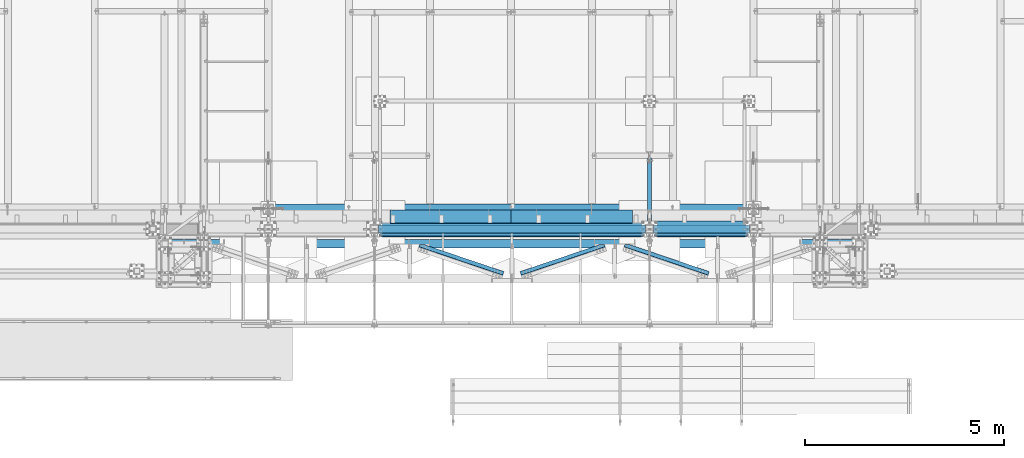
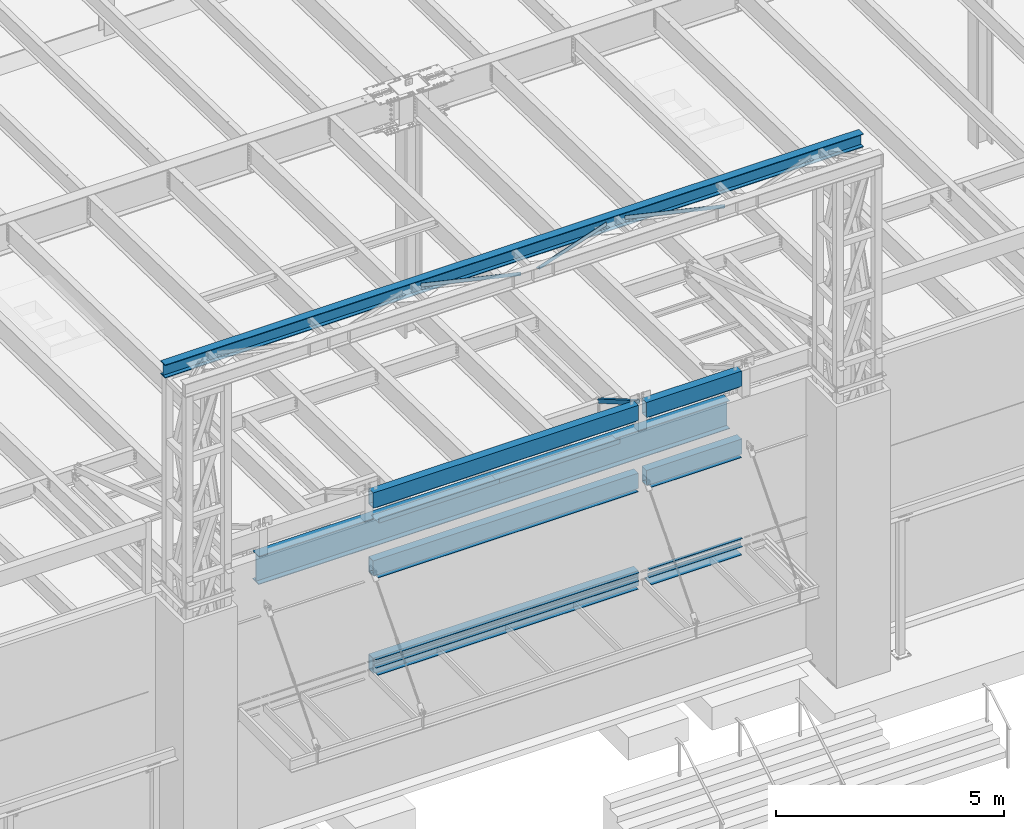
# One storey, part 1057 of 1763: 22 beams, 1 member, 12 elements without a shape of their own.
"""IFC2X3 building model written with IfcOpenShell, lengths in millimetres."""

from ifc_helpers import new_model, si_unit, frame, origin_with_axes, place, context, subcontext, project, spatial, faceted_brep, material, type_object, element, aggregate, save


model = new_model("IFC2X3")

# Units and contexts
model_context = context("Model", 3, precision=1e-05, world=origin_with_axes())
body_context = subcontext(model_context, "Body", "Model", "MODEL_VIEW")
ifc_project = project(units=[si_unit("LENGTHUNIT", "METRE", prefix="MILLI"), si_unit("AREAUNIT", "SQUARE_METRE"), si_unit("VOLUMEUNIT", "CUBIC_METRE"), si_unit("MASSUNIT", "GRAM", prefix="KILO"), si_unit("TIMEUNIT", "SECOND"), si_unit("PLANEANGLEUNIT", "RADIAN"), si_unit("SOLIDANGLEUNIT", "STERADIAN"), si_unit("THERMODYNAMICTEMPERATUREUNIT", "DEGREE_CELSIUS"), si_unit("LUMINOUSINTENSITYUNIT", "LUMEN")], contexts=[model_context])

# Site, building, storey
site_placement = place(None, origin_with_axes())
site = spatial("IfcSite", under=ifc_project, at=site_placement, CompositionType="ELEMENT")
building_placement = place(site_placement, origin_with_axes())
building = spatial("IfcBuilding", under=site, at=building_placement, Name="Undefined", CompositionType="ELEMENT")
storey_placement = place(building_placement, origin_with_axes())
storey = spatial("IfcBuildingStorey", under=building, at=storey_placement, Name="Undefined", CompositionType="ELEMENT", Elevation=0.0)

# Assembly, beam
assembly_1_placement = place(storey_placement, origin_with_axes())
assembly_1 = element("IfcElementAssembly", 1, at=assembly_1_placement, inside=storey, Name="BEAM", AssemblyPlace="NOTDEFINED", PredefinedType="RIGID_FRAME")
ifc_material_1 = material()
beam_type_1 = type_object("IfcBeamType", Name="HSS16X8X5/8", PredefinedType="NOTDEFINED")
beam_1_placement = place(assembly_1_placement, frame((-51917.027008321, -14208.1275869816, 13055.6221257957), z_axis=(0.0, 0.0, 1.0), x_axis=(1.0, 0.0, 0.0)))
beam_1 = element("IfcBeam", 2, at=beam_1_placement, type_object=beam_type_1, material=ifc_material_1, Name="BEAM", ObjectType="HSS16X8X5/8", context=body_context, shape_type="Brep", body=[
    faceted_brep([(0.0, 85.7250000000058, -187.325), (0.0, -85.7250000000058, -187.325), (2413.00000000001, -85.7250000000004, -187.325000000001), (2413.00000000001, 85.7250000000004, -187.325000000001), (0.0, -85.7250000000058, 187.325), (2413.00000000001, -85.7250000000004, 187.325000000001), (0.0, 85.7250000000058, 187.325), (2413.00000000001, 85.7250000000004, 187.325000000001), (0.0, 101.600000000006, -203.2), (0.0, 101.600000000006, 203.2), (2413.00000000001, 101.6, 203.200000000001), (2413.00000000001, 101.6, -203.200000000001), (0.0, -101.600000000006, 203.2), (2413.00000000001, -101.6, 203.200000000001), (0.0, -101.600000000006, -203.2), (2413.00000000001, -101.6, -203.200000000001)], [[[0, 1, 2, 3]], [[1, 4, 5, 2]], [[4, 6, 7, 5]], [[6, 0, 3, 7]], [[8, 9, 10, 11]], [[9, 12, 13, 10]], [[12, 14, 15, 13]], [[14, 8, 11, 15]], [[13, 15, 11, 10], [5, 7, 3, 2]], [[14, 12, 9, 8], [6, 4, 1, 0]]]),
])

assembly_2_placement = place(storey_placement, origin_with_axes())
assembly_2 = element("IfcElementAssembly", 3, at=assembly_2_placement, inside=storey, Name="BEAM", AssemblyPlace="NOTDEFINED", PredefinedType="RIGID_FRAME")
beam_2_placement = place(assembly_2_placement, frame((-58825.8276803548, -14208.1276214906, 13055.6221257968), z_axis=(3.29999999667052e-06, 0.0, 0.999999999994555), x_axis=(0.999999999994883, 4.99999977045952e-09, -3.19899999977773e-06)))
beam_2 = element("IfcBeam", 4, at=beam_2_placement, type_object=beam_type_1, material=ifc_material_1, Name="BEAM", ObjectType="HSS16X8X5/8", context=body_context, shape_type="Brep", body=[
    faceted_brep([(0.0, 85.7250000000058, -187.325), (0.0, -85.7250000000058, -187.325), (6705.60000152276, -85.7249999973046, -187.324999997729), (6705.60000152301, 85.7250000026943, -187.324999997732), (0.0, -85.7250000000058, 187.325), (6705.60000152401, -85.7249999973046, 187.325000002267), (0.0, 85.7250000000058, 187.325), (6705.60000152425, 85.7250000026943, 187.325000002264), (0.0, 101.600000000006, -203.2), (0.0, 101.600000000006, 203.2), (6705.60000152433, 101.600000002694, 203.200000002264), (6705.60000152298, 101.600000002694, -203.199999997731), (0.0, -101.600000000006, 203.2), (6705.60000152404, -101.599999997305, 203.200000002267), (0.0, -101.600000000006, -203.2), (6705.6000015227, -101.599999997305, -203.199999997727)], [[[0, 1, 2, 3]], [[1, 4, 5, 2]], [[4, 6, 7, 5]], [[6, 0, 3, 7]], [[8, 9, 10, 11]], [[9, 12, 13, 10]], [[12, 14, 15, 13]], [[14, 8, 11, 15]], [[13, 15, 11, 10], [5, 7, 3, 2]], [[14, 12, 9, 8], [6, 4, 1, 0]]]),
])

assembly_3_placement = place(storey_placement, origin_with_axes())
assembly_3 = element("IfcElementAssembly", 5, at=assembly_3_placement, inside=storey, Name="BEAM", AssemblyPlace="NOTDEFINED", PredefinedType="RIGID_FRAME")
beam_3_placement = place(assembly_3_placement, frame((-58825.8270098567, -14208.1276214906, 11239.5), z_axis=(0.0, 0.0, 1.0), x_axis=(1.0, 0.0, 0.0)))
beam_3 = element("IfcBeam", 6, at=beam_3_placement, type_object=beam_type_1, material=ifc_material_1, Name="BEAM", ObjectType="HSS16X8X5/8", context=body_context, shape_type="Brep", body=[
    faceted_brep([(0.0, 85.7250000000058, -187.325), (0.0, -85.7250000000058, -187.325), (6705.60000152276, -85.7249999973046, -187.324999997729), (6705.60000152301, 85.7250000026943, -187.324999997732), (0.0, -85.7250000000058, 187.325), (6705.60000152401, -85.7249999973046, 187.325000002267), (0.0, 85.7250000000058, 187.325), (6705.60000152425, 85.7250000026943, 187.325000002264), (0.0, 101.600000000006, -203.2), (0.0, 101.600000000006, 203.2), (6705.60000152433, 101.600000002694, 203.200000002264), (6705.60000152298, 101.600000002694, -203.199999997731), (0.0, -101.600000000006, 203.2), (6705.60000152404, -101.599999997305, 203.200000002267), (0.0, -101.600000000006, -203.2), (6705.6000015227, -101.599999997305, -203.199999997727)], [[[0, 1, 2, 3]], [[1, 4, 5, 2]], [[4, 6, 7, 5]], [[6, 0, 3, 7]], [[8, 9, 10, 11]], [[9, 12, 13, 10]], [[12, 14, 15, 13]], [[14, 8, 11, 15]], [[13, 15, 11, 10], [5, 7, 3, 2]], [[14, 12, 9, 8], [6, 4, 1, 0]]]),
])

assembly_4_placement = place(storey_placement, origin_with_axes())
assembly_4 = element("IfcElementAssembly", 7, at=assembly_4_placement, inside=storey, Name="BEAM", AssemblyPlace="NOTDEFINED", PredefinedType="RIGID_FRAME")
beam_4_placement = place(assembly_4_placement, frame((-58825.8270098567, -14208.1276214906, 8636.0), z_axis=(0.0, 0.0, 1.0), x_axis=(1.0, 0.0, 0.0)))
beam_4 = element("IfcBeam", 8, at=beam_4_placement, type_object=beam_type_1, material=ifc_material_1, Name="BEAM", ObjectType="HSS16X8X5/8", context=body_context, shape_type="Brep", body=[
    faceted_brep([(0.0, 85.7250000000058, -187.325), (0.0, -85.7250000000058, -187.325), (6705.60000152276, -85.7249999973046, -187.324999997729), (6705.60000152301, 85.7250000026943, -187.324999997732), (0.0, -85.7250000000058, 187.325), (6705.60000152401, -85.7249999973046, 187.325000002267), (0.0, 85.7250000000058, 187.325), (6705.60000152425, 85.7250000026943, 187.325000002264), (0.0, 101.600000000006, -203.2), (0.0, 101.600000000006, 203.2), (6705.60000152433, 101.600000002694, 203.200000002264), (6705.60000152298, 101.600000002694, -203.199999997731), (0.0, -101.600000000006, 203.2), (6705.60000152404, -101.599999997305, 203.200000002267), (0.0, -101.600000000006, -203.2), (6705.6000015227, -101.599999997305, -203.199999997727)], [[[0, 1, 2, 3]], [[1, 4, 5, 2]], [[4, 6, 7, 5]], [[6, 0, 3, 7]], [[8, 9, 10, 11]], [[9, 12, 13, 10]], [[12, 14, 15, 13]], [[14, 8, 11, 15]], [[13, 15, 11, 10], [5, 7, 3, 2]], [[14, 12, 9, 8], [6, 4, 1, 0]]]),
])

assembly_5_placement = place(storey_placement, origin_with_axes())
assembly_5 = element("IfcElementAssembly", 9, at=assembly_5_placement, inside=storey, Name="ANGLE", AssemblyPlace="NOTDEFINED", PredefinedType="RIGID_FRAME")
ifc_material_2 = material(Name="STEEL/A36")
beam_type_2 = type_object("IfcBeamType", Name="L4X4X1/4", PredefinedType="NOTDEFINED")
beam_5_placement = place(assembly_5_placement, frame((-52877.5798431206, -14531.4847231147, 18672.175), z_axis=(0.320655196883025, 0.947195990654473, 0.0), x_axis=(0.947195990654472, -0.320655196883028, 0.0)))
beam_5 = element("IfcBeam", 10, at=beam_5_placement, type_object=beam_type_2, material=ifc_material_2, Name="ANGLE", ObjectType="L4X4X1/4", context=body_context, shape_type="Brep", body=[
    faceted_brep([(248.960001879874, 44.4500000000007, 15.1976981958214), (248.960001879874, 50.7999999999993, 15.1976981958214), (248.955725224791, 50.7999999999993, -50.8000000003522), (248.955725224791, -50.7999999999993, -50.8000000003522), (248.956127270321, -50.7999999999993, -44.4500000003463), (248.956127270321, 44.4500000000007, -44.4500000003463), (354.602873441865, 44.4500000000007, 50.953844037489), (354.602873441872, 50.7999999999993, 50.7999999995773), (2474.00619453916, -50.7999999999993, -44.4500000031403), (2474.00578204374, -50.7999999999993, -50.8000000031461), (2474.00578204374, 50.7999999999993, -50.8000000031461), (2474.01238197072, 50.7999999999993, 50.7999999969179), (2474.01238197072, 44.4500000000007, 50.7999999969179), (2474.00619453916, 44.4500000000007, -44.4500000031403)], [[[0, 1, 2, 3, 4, 5]], [[6, 7, 1, 0]], [[8, 9, 10, 11, 12, 13]], [[5, 13, 12, 6, 0]], [[8, 13, 5, 4]], [[9, 8, 4, 3]], [[10, 9, 3, 2]], [[11, 10, 2, 1, 7]], [[12, 11, 7, 6]]]),
])
aggregate(assembly_5, [beam_5])

assembly_6_placement = place(storey_placement, origin_with_axes())
assembly_6 = element("IfcElementAssembly", 11, at=assembly_6_placement, inside=storey, Name="ANGLE", AssemblyPlace="NOTDEFINED", PredefinedType="RIGID_FRAME")
beam_6_placement = place(assembly_6_placement, frame((-58035.8965740268, -14531.4846908502, 18672.175), z_axis=(0.320655196883025, 0.947195990654473, 0.0), x_axis=(0.947195990654472, -0.320655196883028, 0.0)))
beam_6 = element("IfcBeam", 12, at=beam_6_placement, type_object=beam_type_2, material=ifc_material_2, Name="ANGLE", ObjectType="L4X4X1/4", context=body_context, shape_type="Brep", body=[
    faceted_brep([(248.960001879874, 44.4500000000007, 15.1976981958214), (248.960001879874, 50.7999999999993, 15.1976981958214), (248.955725224791, 50.7999999999993, -50.8000000003522), (248.955725224791, -50.7999999999993, -50.8000000003522), (248.956127270321, -50.7999999999993, -44.4500000003463), (248.956127270321, 44.4500000000007, -44.4500000003463), (354.602873441865, 44.4500000000007, 50.953844037489), (354.602873441872, 50.7999999999993, 50.7999999995773), (2474.00619453916, -50.7999999999993, -44.4500000031403), (2474.00578204374, -50.7999999999993, -50.8000000031461), (2474.00578204374, 50.7999999999993, -50.8000000031461), (2474.01238197072, 50.7999999999993, 50.7999999969179), (2474.01238197072, 44.4500000000007, 50.7999999969179), (2474.00619453916, 44.4500000000007, -44.4500000031403)], [[[0, 1, 2, 3, 4, 5]], [[6, 7, 1, 0]], [[8, 9, 10, 11, 12, 13]], [[5, 13, 12, 6, 0]], [[8, 13, 5, 4]], [[9, 8, 4, 3]], [[10, 9, 3, 2]], [[11, 10, 2, 1, 7]], [[12, 11, 7, 6]]]),
])
aggregate(assembly_6, [beam_6])

assembly_7_placement = place(storey_placement, origin_with_axes())
assembly_7 = element("IfcElementAssembly", 13, at=assembly_7_placement, inside=storey, Name="ANGLE", AssemblyPlace="NOTDEFINED", PredefinedType="RIGID_FRAME")
beam_7_placement = place(assembly_7_placement, frame((-55489.316785198, -15404.6097572214, 18672.175), z_axis=(-0.320655214854611, 0.947195984570534, 0.0), x_axis=(0.947195984570534, 0.320655214854612, 0.0)))
beam_7 = element("IfcBeam", 14, at=beam_7_placement, type_object=beam_type_2, material=ifc_material_2, Name="ANGLE", ObjectType="L4X4X1/4", context=body_context, shape_type="Brep", body=[
    faceted_brep([(2473.90666734029, 44.4500000000007, 14.9212591829789), (2473.90666734029, 50.7999999999993, 14.9212591829789), (2368.26819304615, 50.7999999999993, 50.8000000021136), (2368.26819304615, 44.4500000000007, 50.8000000021136), (2473.90322387923, 44.4500000000007, -44.4499999977991), (2473.90322387923, -50.7999999999993, -44.4499999977991), (2473.90284887469, -50.7999999999993, -50.7999999978013), (2473.90284887469, 50.7999999999993, -50.7999999978013), (248.852789269382, 50.7999999999993, -50.7999999997803), (248.852789269382, -50.7999999999993, -50.7999999997803), (248.853157555044, -50.7999999999993, -44.4499999997781), (248.853157555044, 44.4500000000007, -44.4499999997781), (248.858681840073, 44.4500000000007, 50.8000000002273), (248.858681840073, 50.7999999999993, 50.8000000002273)], [[[0, 1, 2, 3]], [[4, 5, 6, 7, 1, 0]], [[8, 9, 10, 11, 12, 13]], [[13, 12, 3, 2]], [[8, 13, 2, 1, 7]], [[9, 8, 7, 6]], [[10, 9, 6, 5]], [[11, 10, 5, 4]], [[12, 11, 4, 0, 3]]]),
])
aggregate(assembly_7, [beam_7])

assembly_8_placement = place(storey_placement, origin_with_axes())
assembly_8 = element("IfcElementAssembly", 15, at=assembly_8_placement, inside=storey, Name="BEAM", AssemblyPlace="NOTDEFINED", PredefinedType="RIGID_FRAME")
beam_type_3 = type_object("IfcBeamType", Name="HSS16X8X1/4", PredefinedType="NOTDEFINED")
beam_8_placement = place(assembly_8_placement, frame((-51917.027008321, -14208.1275869816, 11239.5), z_axis=(0.0, 0.0, 1.0), x_axis=(1.0, 0.0, 0.0)))
beam_8 = element("IfcBeam", 16, at=beam_8_placement, type_object=beam_type_3, material=ifc_material_1, Name="BEAM", ObjectType="HSS16X8X1/4", context=body_context, shape_type="Brep", body=[
    faceted_brep([(0.0, 95.25, -196.85), (0.0, -95.25, -196.85), (2413.00000000001, -95.25, -196.85), (2413.00000000001, 95.25, -196.85), (0.0, -95.25, 196.85), (2413.00000000001, -95.25, 196.85), (0.0, 95.25, 196.85), (2413.00000000001, 95.25, 196.85), (0.0, 101.600000000006, -203.2), (0.0, 101.600000000006, 203.2), (2413.00000000001, 101.6, 203.200000000001), (2413.00000000001, 101.6, -203.200000000001), (0.0, -101.600000000006, 203.2), (2413.00000000001, -101.6, 203.200000000001), (0.0, -101.600000000006, -203.2), (2413.00000000001, -101.6, -203.200000000001)], [[[0, 1, 2, 3]], [[1, 4, 5, 2]], [[4, 6, 7, 5]], [[6, 0, 3, 7]], [[8, 9, 10, 11]], [[9, 12, 13, 10]], [[12, 14, 15, 13]], [[14, 8, 11, 15]], [[13, 15, 11, 10], [5, 7, 3, 2]], [[14, 12, 9, 8], [6, 4, 1, 0]]]),
])

# Assembly, member
assembly_9_placement = place(storey_placement, origin_with_axes())
assembly_9 = element("IfcElementAssembly", 17, at=assembly_9_placement, inside=storey, Name="V. BRACE", AssemblyPlace="NOTDEFINED", PredefinedType="RIGID_FRAME")
member_type = type_object("IfcMemberType", Name="HSS4X4X3/8", PredefinedType="NOTDEFINED")
member_placement = place(assembly_9_placement, frame((-52018.6372736983, -14106.5252407814, 13182.6000019665), z_axis=(0.0, 0.50173172990702, 0.865023277839683), x_axis=(0.0, 0.865023198927323, -0.501731865957846)))
member = element("IfcMember", 18, at=member_placement, type_object=member_type, material=ifc_material_1, Name="V. BRACE", ObjectType="HSS4X4X3/8", context=body_context, shape_type="Brep", body=[
    faceted_brep([(1908.23772841777, 7.93799800872512, 50.8000000000602), (1825.68772536952, 7.93799800872512, 50.8000000000566), (1825.68772536952, 7.93799800872512, 41.2750000000642), (1908.23772841777, 7.93799800872512, 41.2750000000669), (1825.68772536952, -7.93700008401356, 50.8000000000566), (1825.68772536952, -7.93700008401356, 41.2750000000642), (1908.23772842113, -7.93700008392625, 50.800000000062), (1908.23772841777, -7.93700008392625, 41.2750000000669), (1908.23772841777, 7.93799800872512, -41.2749999998796), (1825.68772536953, 7.93799800872512, -41.274999999885), (1825.68772536953, 7.93799800872512, -50.7999999998774), (1908.23772841777, 7.93799800872512, -50.7999999998729), (1825.68772536953, -7.93700008401356, -41.274999999885), (1825.68772536953, -7.93700008401356, -50.7999999998774), (1908.23772842113, -7.93700008392625, -41.2749999998796), (1908.23772841777, -7.93700008392625, -50.7999999998729), (-23.943093575228, 41.2750000000015, 41.2749999999705), (23.9376633641841, 41.2750000000015, -41.2749999999724), (1908.23772841777, 41.2750000000015, -41.2749999998796), (1908.23772841777, 41.2750000000015, 41.2750000000669), (1908.23772841777, -41.2750000000015, 41.2750000000669), (-23.943093575228, -41.2750000000015, 41.2749999999705), (23.9376633641841, -41.2750000000015, -41.2749999999724), (1908.23772841777, -41.2750000000015, -41.2749999998796), (29.4623660879624, -50.8000000000029, -50.7999999999665), (-29.4677962990063, -50.8000000000029, 50.7999999999647), (-29.4677962990063, 50.8000000000029, 50.7999999999647), (29.4623660879624, 50.8000000000029, -50.7999999999665), (1908.23772841777, 50.8000000000029, 50.8000000000602), (1908.23772841777, 50.8000000000029, -50.7999999998729), (1908.23772841777, -50.8000000000029, -50.7999999998729), (1908.23772841777, -50.8000000000029, 50.8000000000602)], [[[0, 1, 2, 3]], [[4, 5, 2, 1]], [[6, 7, 5, 4]], [[8, 9, 10, 11]], [[12, 13, 10, 9]], [[14, 15, 13, 12]], [[16, 17, 18, 19]], [[20, 21, 16, 19, 3, 2, 5, 7]], [[22, 21, 20, 23]], [[9, 8, 18, 17, 22, 23, 14, 12]], [[24, 25, 26, 27], [16, 21, 22, 17]], [[27, 26, 28, 29]], [[19, 18, 8, 11, 29, 28, 0, 3]], [[30, 24, 27, 29, 11, 10, 13, 15]], [[25, 24, 30, 31]], [[1, 0, 28, 26, 25, 31, 6, 4]], [[31, 30, 15, 14, 23, 20, 7, 6]]]),
])
aggregate(assembly_9, [member])

# Assembly, beam
assembly_10_placement = place(storey_placement, origin_with_axes())
assembly_10 = element("IfcElementAssembly", 19, at=assembly_10_placement, inside=storey, Name="BEAM", AssemblyPlace="NOTDEFINED", PredefinedType="RIGID_FRAME")
beam_type_4 = type_object("IfcBeamType", Name="L3X3X3/8", PredefinedType="NOTDEFINED")
beam_9_placement = place(assembly_10_placement, frame((-49529.4267564555, -14347.8275817909, 8648.7), z_axis=(0.0, -1.0, 0.0), x_axis=(-1.0, 0.0, 0.0)))
beam_9 = element("IfcBeam", 20, at=beam_9_placement, type_object=beam_type_4, material=ifc_material_2, Name="ANGLE", ObjectType="L3X3X3/8", context=body_context, shape_type="Brep", body=[
    faceted_brep([(0.0, 38.0999999999985, -38.1000000000004), (0.0, 38.0999999999985, 38.1000000000004), (2362.20045158143, 38.1000000000004, 38.1000000001986), (2362.20045158116, 38.1000000000004, -38.0999999998003), (1.45519152283669e-11, 28.5750000000007, 38.1000000000022), (2362.20045158143, 28.5750000000007, 38.1000000001986), (0.0, 28.5750000000007, -28.5750000000007), (2362.20045158119, 28.5750000000007, -28.5749999998006), (0.0, -38.1000000000004, -28.5750000000007), (2362.20045158119, -38.1000000000004, -28.5749999998006), (0.0, -38.0999999999985, -38.1000000000004), (2362.20045158116, -38.1000000000004, -38.0999999998003)], [[[0, 1, 2, 3]], [[1, 4, 5, 2]], [[4, 6, 7, 5]], [[6, 8, 9, 7]], [[8, 10, 11, 9]], [[10, 0, 3, 11]], [[5, 7, 9, 11, 3, 2]], [[10, 8, 6, 4, 1, 0]]]),
])

# Beam
beam_10_placement = place(assembly_4_placement, frame((-52145.6272594463, -14347.827595127, 8648.7), z_axis=(0.0, -1.0, 0.0), x_axis=(-1.0, 0.0, 0.0)))
beam_10 = element("IfcBeam", 21, at=beam_10_placement, type_object=beam_type_4, material=ifc_material_2, Name="ANGLE", ObjectType="L3X3X3/8", context=body_context, shape_type="Brep", body=[
    faceted_brep([(0.0, 38.0999999999985, -38.1000000000004), (0.0, 38.0999999999985, 38.1000000000004), (6654.79975039919, 38.1000000000004, 38.1000000000004), (6654.79975039919, 38.1000000000004, -38.1000000000004), (1.45519152283669e-11, 28.5750000000007, 38.1000000000022), (6654.79975039919, 28.5750000000007, 38.1000000000004), (0.0, 28.5750000000007, -28.5750000000007), (6654.79975039919, 28.5750000000007, -28.5750000000007), (0.0, -38.1000000000004, -28.5750000000007), (6654.79975039919, -38.1000000000004, -28.5750000000007), (0.0, -38.0999999999985, -38.1000000000004), (6654.79975039919, -38.1000000000004, -38.1000000000004)], [[[0, 1, 2, 3]], [[1, 4, 5, 2]], [[4, 6, 7, 5]], [[6, 8, 9, 7]], [[8, 10, 11, 9]], [[10, 0, 3, 11]], [[5, 7, 9, 11, 3, 2]], [[10, 8, 6, 4, 1, 0]]]),
])

beam_type_5 = type_object("IfcBeamType", Name="L4X3X3/8", PredefinedType="NOTDEFINED")
beam_11_placement = place(assembly_10_placement, frame((-49529.4267564555, -14347.8275900397, 8788.4), z_axis=(0.0, 0.0, -1.0), x_axis=(-1.0, 0.0, 0.0)))
beam_11 = element("IfcBeam", 22, at=beam_11_placement, type_object=beam_type_5, material=ifc_material_2, Name="ANGLE", ObjectType="L4X3X3/8", context=body_context, shape_type="Brep", body=[
    faceted_brep([(1.45519152283669e-10, 38.0999999999985, -50.7999999999993), (1.45519152283669e-10, 38.0999999999985, 50.7999999999993), (2362.20045158116, 38.0999999998003, 50.7999999999993), (2362.20045158116, 38.0999999998003, -50.7999999999993), (1.09139364212751e-10, 28.5749999999989, 50.7999999999993), (2362.20045158119, 28.5749999998006, 50.7999999999993), (1.09139364212751e-10, 28.5749999999989, -41.2749999999996), (2362.20045158119, 28.5749999998006, -41.2749999999996), (-1.23691279441118e-10, -38.1000000000022, -41.2749999999996), (2362.20045158143, -38.1000000001986, -41.2749999999996), (-1.23691279441118e-10, -38.1000000000022, -50.7999999999993), (2362.20045158143, -38.1000000001986, -50.7999999999993)], [[[0, 1, 2, 3]], [[1, 4, 5, 2]], [[4, 6, 7, 5]], [[6, 8, 9, 7]], [[8, 10, 11, 9]], [[10, 0, 3, 11]], [[5, 7, 9, 11, 3, 2]], [[10, 8, 6, 4, 1, 0]]]),
])

beam_12_placement = place(assembly_4_placement, frame((-52145.6272594463, -14347.8276033757, 8788.4), z_axis=(0.0, 0.0, -1.0), x_axis=(-1.0, 0.0, 0.0)))
beam_12 = element("IfcBeam", 23, at=beam_12_placement, type_object=beam_type_5, material=ifc_material_2, Name="ANGLE", ObjectType="L4X3X3/8", context=body_context, shape_type="Brep", body=[
    faceted_brep([(1.45519152283669e-10, 38.0999999999985, -50.7999999999993), (1.45519152283669e-10, 38.0999999999985, 50.7999999999993), (6654.79975039919, 38.1000000000004, 50.7999999999993), (6654.79975039919, 38.1000000000004, -50.7999999999993), (1.09139364212751e-10, 28.5749999999989, 50.7999999999993), (6654.79975039919, 28.5750000000007, 50.7999999999993), (1.09139364212751e-10, 28.5749999999989, -41.2749999999996), (6654.79975039919, 28.5750000000007, -41.2749999999996), (-1.23691279441118e-10, -38.1000000000022, -41.2749999999996), (6654.79975039919, -38.1000000000004, -41.2749999999996), (-1.23691279441118e-10, -38.1000000000022, -50.7999999999993), (6654.79975039919, -38.1000000000004, -50.7999999999993)], [[[0, 1, 2, 3]], [[1, 4, 5, 2]], [[4, 6, 7, 5]], [[6, 8, 9, 7]], [[8, 10, 11, 9]], [[10, 0, 3, 11]], [[5, 7, 9, 11, 3, 2]], [[10, 8, 6, 4, 1, 0]]]),
])

beam_type_6 = type_object("IfcBeamType", PredefinedType="NOTDEFINED")
beam_13_placement = place(assembly_1_placement, frame((-51853.5283726658, -14157.3276003233, 12846.0809375628), z_axis=(0.0, 1.0, 0.0), x_axis=(0.999999999994883, 4.99999977045952e-09, -3.19899999977773e-06)))
beam_13 = element("IfcBeam", 24, at=beam_13_placement, type_object=beam_type_6, material=ifc_material_2, Name="PLATE", context=body_context, shape_type="Brep", body=[
    faceted_brep([(-2.11002770811319e-10, 6.34999999999854, -152.4), (2.25554686039686e-10, 6.34999999999854, 152.4), (2285.99882570394, 6.3500000001477, 152.400000000918), (2285.99882570351, 6.3500000001477, -152.399999999081), (2.11002770811319e-10, -6.34999999999854, 152.399999999998), (2285.9988257039, -6.34999999985666, 152.400000000918), (-2.25554686039686e-10, -6.34999999999854, -152.400000000001), (2285.99882570346, -6.34999999985666, -152.399999999081)], [[[0, 1, 2, 3]], [[1, 4, 5, 2]], [[4, 6, 7, 5]], [[6, 0, 3, 7]], [[5, 7, 3, 2]], [[6, 4, 1, 0]]]),
])

aggregate(assembly_1, [beam_13, beam_1])

beam_14_placement = place(assembly_2_placement, frame((-58762.3283730595, -14157.3276348474, 12846.1037327647), z_axis=(0.0, 1.0, 0.0), x_axis=(0.999999999994883, 4.99999977045952e-09, -3.19899999977773e-06)))
beam_14 = element("IfcBeam", 25, at=beam_14_placement, type_object=beam_type_6, material=ifc_material_2, Name="PLATE", context=body_context, shape_type="Brep", body=[
    faceted_brep([(-2.11002770811319e-10, 6.34999999999854, -152.4), (2.25554686039686e-10, 6.34999999999854, 152.4), (6578.59882648884, 6.34999999485444, 152.400000002643), (6578.59882648841, 6.34999999485444, -152.399999997358), (2.11002770811319e-10, -6.34999999999854, 152.399999999998), (6578.59882648884, -6.35000000514628, 152.400000002641), (-2.25554686039686e-10, -6.34999999999854, -152.400000000001), (6578.5988264884, -6.35000000514628, -152.399999997358)], [[[0, 1, 2, 3]], [[1, 4, 5, 2]], [[4, 6, 7, 5]], [[6, 0, 3, 7]], [[5, 7, 3, 2]], [[6, 4, 1, 0]]]),
])

aggregate(assembly_2, [beam_14, beam_2])

beam_15_placement = place(assembly_8_placement, frame((-51853.5270082575, -14258.9275736586, 11029.95), z_axis=(0.0, 1.0, 0.0), x_axis=(1.0, 0.0, 0.0)))
beam_15 = element("IfcBeam", 26, at=beam_15_placement, type_object=beam_type_6, material=ifc_material_2, Name="PLATE", context=body_context, shape_type="Brep", body=[
    faceted_brep([(-2.11002770811319e-10, 6.34999999999854, -152.4), (2.25554686039686e-10, 6.34999999999854, 152.4), (2285.99882570394, 6.3500000001477, 152.400000000918), (2285.99882570351, 6.3500000001477, -152.399999999081), (2.11002770811319e-10, -6.34999999999854, 152.399999999998), (2285.9988257039, -6.34999999985666, 152.400000000918), (-2.25554686039686e-10, -6.34999999999854, -152.400000000001), (2285.99882570346, -6.34999999985666, -152.399999999081)], [[[0, 1, 2, 3]], [[1, 4, 5, 2]], [[4, 6, 7, 5]], [[6, 0, 3, 7]], [[5, 7, 3, 2]], [[6, 4, 1, 0]]]),
])

aggregate(assembly_8, [beam_15, beam_8])

beam_16_placement = place(assembly_3_placement, frame((-58762.3270092855, -14258.9276081701, 11029.95), z_axis=(0.0, 1.0, 0.0), x_axis=(1.0, 0.0, 0.0)))
beam_16 = element("IfcBeam", 27, at=beam_16_placement, type_object=beam_type_6, material=ifc_material_2, Name="PLATE", context=body_context, shape_type="Brep", body=[
    faceted_brep([(-2.11002770811319e-10, 6.34999999999854, -152.4), (2.25554686039686e-10, 6.34999999999854, 152.4), (6578.59882648884, 6.34999999485444, 152.400000002643), (6578.59882648841, 6.34999999485444, -152.399999997358), (2.11002770811319e-10, -6.34999999999854, 152.399999999998), (6578.59882648884, -6.35000000514628, 152.400000002641), (-2.25554686039686e-10, -6.34999999999854, -152.400000000001), (6578.5988264884, -6.35000000514628, -152.399999997358)], [[[0, 1, 2, 3]], [[1, 4, 5, 2]], [[4, 6, 7, 5]], [[6, 0, 3, 7]], [[5, 7, 3, 2]], [[6, 4, 1, 0]]]),
])

aggregate(assembly_3, [beam_16, beam_3])

beam_17_placement = place(assembly_10_placement, frame((-51853.5270082574, -14258.9275736712, 8426.45), z_axis=(0.0, 1.0, 0.0), x_axis=(1.0, 0.0, 0.0)))
beam_17 = element("IfcBeam", 28, at=beam_17_placement, type_object=beam_type_6, material=ifc_material_2, Name="PLATE", context=body_context, shape_type="Brep", body=[
    faceted_brep([(-2.11002770811319e-10, 6.34999999999854, -152.4), (2.25554686039686e-10, 6.34999999999854, 152.4), (2285.99882570394, 6.3500000001477, 152.400000000918), (2285.99882570351, 6.3500000001477, -152.399999999081), (2.11002770811319e-10, -6.34999999999854, 152.399999999998), (2285.9988257039, -6.34999999985666, 152.400000000918), (-2.25554686039686e-10, -6.34999999999854, -152.400000000001), (2285.99882570346, -6.34999999985666, -152.399999999081)], [[[0, 1, 2, 3]], [[1, 4, 5, 2]], [[4, 6, 7, 5]], [[6, 0, 3, 7]], [[5, 7, 3, 2]], [[6, 4, 1, 0]]]),
])

aggregate(assembly_10, [beam_9, beam_11, beam_17])

beam_18_placement = place(assembly_4_placement, frame((-58762.3270092854, -14258.9276081703, 8426.45), z_axis=(0.0, 1.0, 0.0), x_axis=(1.0, 0.0, 0.0)))
beam_18 = element("IfcBeam", 29, at=beam_18_placement, type_object=beam_type_6, material=ifc_material_2, Name="PLATE", context=body_context, shape_type="Brep", body=[
    faceted_brep([(-2.11002770811319e-10, 6.34999999999854, -152.4), (2.25554686039686e-10, 6.34999999999854, 152.4), (6578.59882648884, 6.34999999485444, 152.400000002643), (6578.59882648841, 6.34999999485444, -152.399999997358), (2.11002770811319e-10, -6.34999999999854, 152.399999999998), (6578.59882648884, -6.35000000514628, 152.400000002641), (-2.25554686039686e-10, -6.34999999999854, -152.400000000001), (6578.5988264884, -6.35000000514628, -152.399999997358)], [[[0, 1, 2, 3]], [[1, 4, 5, 2]], [[4, 6, 7, 5]], [[6, 0, 3, 7]], [[5, 7, 3, 2]], [[6, 4, 1, 0]]]),
])

aggregate(assembly_4, [beam_10, beam_12, beam_18, beam_4])

# Assembly, beams
assembly_11_placement = place(storey_placement, origin_with_axes())
assembly_11 = element("IfcElementAssembly", 30, at=assembly_11_placement, inside=storey, Name="BEAM", AssemblyPlace="NOTDEFINED", PredefinedType="RIGID_FRAME")
beam_type_7 = type_object("IfcBeamType", PredefinedType="NOTDEFINED")
beam_19_placement = place(assembly_11_placement, frame((-53971.2622736984, -13728.6998186171, 12207.875), z_axis=(-1.0, 0.0, 0.0), x_axis=(0.0, -1.0, 0.0)))
beam_19 = element("IfcBeam", 31, at=beam_19_placement, type_object=beam_type_7, material=ifc_material_2, Name="BENT_PLATE", context=body_context, shape_type="Brep", body=[
    faceted_brep([(0.0, -3.17499999999927, -1523.99999999999), (0.0, -3.17499999999927, 1524.0), (0.0, 3.17499999999927, 1524.0), (0.0, 3.17499999999927, -1523.99999999999), (330.200016784669, 3.17499999999927, 1524.0), (330.200016784669, 3.17499999999927, -1524.0), (336.550018310547, -3.17499999999927, -1524.0), (336.550018310547, -3.17499999999927, 1524.0), (330.19998779297, 123.824998474123, 1524.0), (330.19998779297, 123.824998474123, -1524.0), (336.549987792969, 123.825000000001, 1524.0), (336.549987792969, 123.825000000001, -1524.0)], [[[0, 1, 2, 3]], [[3, 2, 4, 5]], [[1, 0, 6, 7]], [[5, 4, 8, 9]], [[4, 2, 1, 7, 10, 8]], [[7, 6, 11, 10]], [[6, 0, 3, 5, 9, 11]], [[10, 11, 9, 8]]]),
])
beam_20_placement = place(assembly_11_placement, frame((-57019.2622736984, -13728.6998186171, 12207.875), z_axis=(-1.0, 0.0, 0.0), x_axis=(0.0, -1.0, 0.0)))
beam_20 = element("IfcBeam", 32, at=beam_20_placement, type_object=beam_type_7, material=ifc_material_2, Name="BENT_PLATE", context=body_context, shape_type="Brep", body=[
    faceted_brep([(0.0, -3.17499999999927, -1523.99999999999), (0.0, -3.17499999999927, 1524.0), (0.0, 3.17499999999927, 1524.0), (0.0, 3.17499999999927, -1523.99999999999), (330.200016784669, 3.17499999999927, 1524.0), (330.200016784669, 3.17499999999927, -1524.0), (336.550018310547, -3.17499999999927, -1524.0), (336.550018310547, -3.17499999999927, 1524.0), (330.19998779297, 123.824998474123, 1524.0), (330.19998779297, 123.824998474123, -1524.0), (336.549987792969, 123.825000000001, 1524.0), (336.549987792969, 123.825000000001, -1524.0)], [[[0, 1, 2, 3]], [[3, 2, 4, 5]], [[1, 0, 6, 7]], [[5, 4, 8, 9]], [[4, 2, 1, 7, 10, 8]], [[7, 6, 11, 10]], [[6, 0, 3, 5, 9, 11]], [[10, 11, 9, 8]]]),
])

# Assembly, beam
assembly_12_placement = place(storey_placement, origin_with_axes())
assembly_12 = element("IfcElementAssembly", 33, at=assembly_12_placement, inside=storey, Name="BEAM", AssemblyPlace="NOTDEFINED", PredefinedType="RIGID_FRAME")
ifc_material_3 = material(Name="STEEL/A992")
beam_type_8 = type_object("IfcBeamType", Name="W14X53", PredefinedType="NOTDEFINED")
beam_21_placement = place(assembly_12_placement, frame((-64299.5277910131, -14579.6022094127, 18645.1875), z_axis=(0.0, 0.0, 1.0), x_axis=(1.0, 0.0, 0.0)))
beam_21 = element("IfcBeam", 34, at=beam_21_placement, type_object=beam_type_8, material=ifc_material_3, Name="BEAM", ObjectType="W14X53", context=body_context, shape_type="Brep", body=[
    faceted_brep([(2.69210431724787e-10, 101.599999999999, -176.212500000001), (2.69210431724787e-10, 101.599999999999, -158.75), (17652.9549678276, 101.599999985065, -158.75), (17652.9549678276, 101.599999985065, -176.212500000001), (1.45519152283669e-11, 4.76249999999891, -158.75), (17652.9549678274, 4.76249998506501, -158.75), (1.45519152283669e-11, 4.76249999999891, 158.75), (17652.9549678274, 4.76249998506501, 158.75), (2.69210431724787e-10, 101.599999999999, 158.75), (17652.9549678276, 101.599999985065, 158.75), (2.69210431724787e-10, 101.599999999999, 176.212500000001), (17652.9549678276, 101.599999985065, 176.212500000001), (-2.69210431724787e-10, -101.600000000002, 176.212500000001), (17652.9549678271, -101.600000014934, 176.212500000001), (-2.69210431724787e-10, -101.600000000002, 158.75), (17652.9549678271, -101.600000014934, 158.75), (-1.45519152283669e-11, -4.76250000000255, 158.75), (17652.9549678274, -4.76250001493463, 158.75), (-1.45519152283669e-11, -4.76250000000255, -158.75), (17652.9549678274, -4.76250001493463, -158.75), (-2.69210431724787e-10, -101.600000000002, -158.75), (17652.9549678271, -101.600000014934, -158.75), (-2.69210431724787e-10, -101.600000000002, -176.212500000001), (17652.9549678271, -101.600000014934, -176.212500000001)], [[[0, 1, 2, 3]], [[1, 4, 5, 2]], [[4, 6, 7, 5]], [[6, 8, 9, 7]], [[8, 10, 11, 9]], [[10, 12, 13, 11]], [[12, 14, 15, 13]], [[14, 16, 17, 15]], [[16, 18, 19, 17]], [[18, 20, 21, 19]], [[20, 22, 23, 21]], [[22, 0, 3, 23]], [[5, 7, 9, 11, 13, 15, 17, 19, 21, 23, 3, 2]], [[22, 20, 18, 16, 14, 12, 10, 8, 6, 4, 1, 0]]]),
])
aggregate(assembly_12, [beam_21])

# Beam
beam_type_9 = type_object("IfcBeamType", Name="W30X108", PredefinedType="NOTDEFINED")
beam_22_placement = place(assembly_11_placement, frame((-61594.4372736983, -13715.9998186171, 11825.2875), z_axis=(0.0, 0.0, 1.0), x_axis=(1.0, 0.0, 0.0)))
beam_22 = element("IfcBeam", 35, at=beam_22_placement, type_object=beam_type_9, material=ifc_material_3, Name="BEAM", ObjectType="W30X108", context=body_context, shape_type="Brep", body=[
    faceted_brep([(139.699999999997, 7.14374999999927, -360.362499999999), (139.699999999997, 7.14374999999927, 360.362499999999), (12052.3, 7.14374999999927, 360.362499999999), (12052.3, 7.14374999999927, -360.362499999999), (139.699999999997, 133.35, 360.362499999999), (12052.3, 133.35, 360.362499999999), (139.699999999997, 133.35, 379.4125), (12052.3, 133.35, 379.4125), (139.699999999997, -133.35, 379.4125), (12052.3, -133.35, 379.4125), (139.699999999997, -133.35, 360.362499999999), (12052.3, -133.35, 360.362499999999), (139.699999999997, -7.14374999999927, 360.362499999999), (12052.3, -7.14374999999927, 360.362499999999), (139.699999999997, -7.14374999999927, -360.362499999999), (12052.3, -7.14374999999927, -360.362499999999), (139.699999999997, -133.35, -360.362499999999), (12052.3, -133.35, -360.362499999999), (139.699999999997, -133.35, -379.4125), (12052.3, -133.35, -379.4125), (12052.3, 133.35, -379.4125), (12052.3, 133.35, -360.362499999999), (139.699999999997, 133.35, -379.4125), (139.699999999997, 133.35, -360.775), (400.049750000006, 133.35, -360.775), (400.049750000006, 133.35, -360.362499999999), (400.049750000006, 7.74374999999964, -360.362499999999), (139.699999999997, 7.74374999999964, -360.362499999999), (139.699999999997, 7.74374999999964, -360.775), (400.049750000006, 7.74374999999964, -360.775)], [[[0, 1, 2, 3]], [[1, 4, 5, 2]], [[4, 6, 7, 5]], [[6, 8, 9, 7]], [[8, 10, 11, 9]], [[10, 12, 13, 11]], [[12, 14, 15, 13]], [[14, 16, 17, 15]], [[16, 18, 19, 17]], [[3, 2, 5, 7, 9, 11, 13, 15, 17, 19, 20, 21]], [[18, 22, 20, 19]], [[21, 20, 22, 23, 24, 25]], [[0, 3, 21, 25, 26, 27]], [[23, 22, 18, 16, 14, 12, 10, 8, 6, 4, 1, 0, 27, 28]], [[26, 29, 28, 27]], [[25, 24, 29, 26]], [[23, 28, 29, 24]]]),
])

aggregate(assembly_11, [beam_19, beam_20, beam_22])

save(model, "model.ifc")
